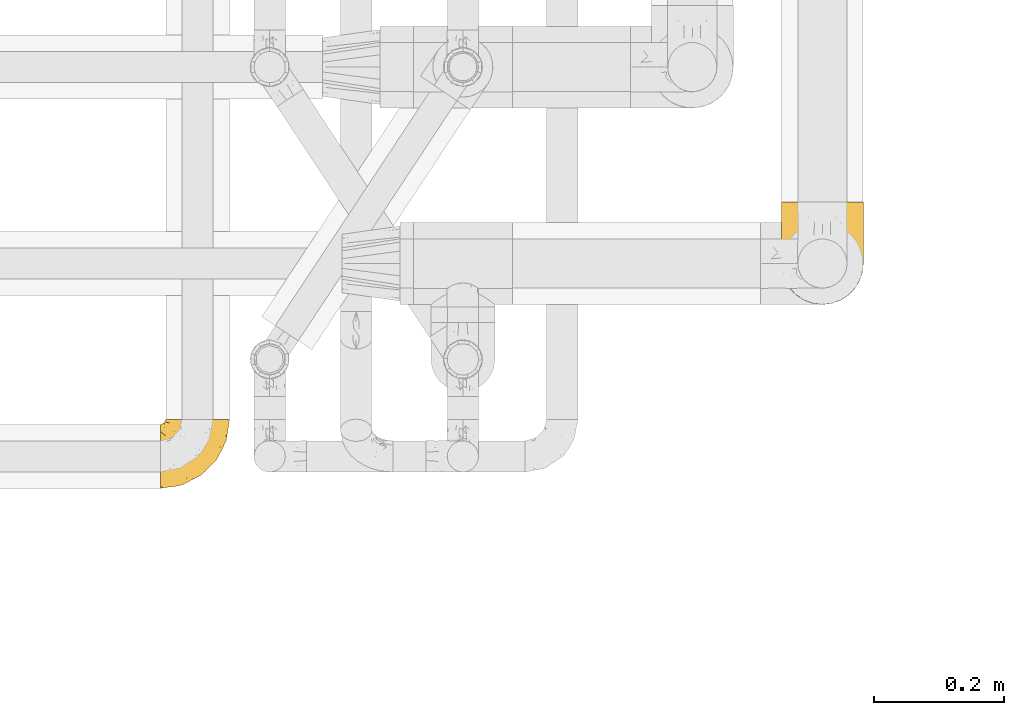
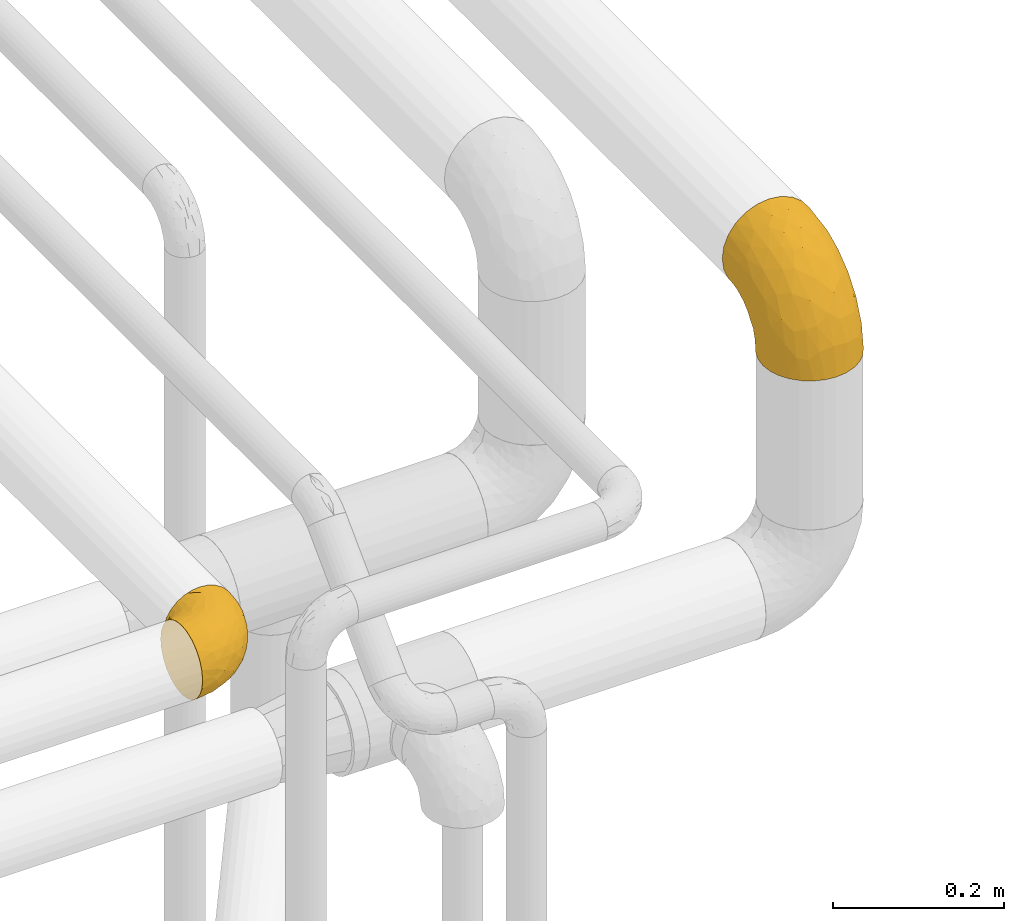
# One storey, part 391 of 827: 2 coverings.
"""IFC2X3 building model written with IfcOpenShell, lengths in millimetres."""

from ifc_helpers import new_model, entity, si_unit, converted_unit, derived_unit, direction, frame, origin, place, context, subcontext, project, spatial, faceted_brep, element, save


model = new_model("IFC2X3")

# Units and contexts
model_context = context("Model", 3, precision=0.01, world=origin(), true_north=direction((6.12303176911189e-17, 1.0)))
body_context = subcontext(model_context, "Body", "Model", "MODEL_VIEW")
ifc_project = project(units=[si_unit("LENGTHUNIT", "METRE", prefix="MILLI"), si_unit("AREAUNIT", "SQUARE_METRE"), si_unit("VOLUMEUNIT", "CUBIC_METRE"), converted_unit("PLANEANGLEUNIT", "DEGREE", entity("IfcRatioMeasure", 0.0174532925199433), si_unit("PLANEANGLEUNIT", "RADIAN"), dimensions=[0, 0, 0, 0, 0, 0, 0]), si_unit("MASSUNIT", "GRAM", prefix="KILO"), derived_unit("MASSDENSITYUNIT", [(si_unit("MASSUNIT", "GRAM", prefix="KILO"), 1), (si_unit("LENGTHUNIT", "METRE"), -3)]), derived_unit("MOMENTOFINERTIAUNIT", [(si_unit("LENGTHUNIT", "METRE"), 4)]), si_unit("TIMEUNIT", "SECOND"), si_unit("FREQUENCYUNIT", "HERTZ"), si_unit("THERMODYNAMICTEMPERATUREUNIT", "DEGREE_CELSIUS"), derived_unit("THERMALTRANSMITTANCEUNIT", [(si_unit("MASSUNIT", "GRAM", prefix="KILO"), 1), (si_unit("THERMODYNAMICTEMPERATUREUNIT", "KELVIN"), -1), (si_unit("TIMEUNIT", "SECOND"), -3)]), derived_unit("VOLUMETRICFLOWRATEUNIT", [(si_unit("LENGTHUNIT", "METRE"), 3), (si_unit("TIMEUNIT", "SECOND"), -1)]), derived_unit("MASSFLOWRATEUNIT", [(si_unit("MASSUNIT", "GRAM", prefix="KILO"), 1), (si_unit("TIMEUNIT", "SECOND"), -1)]), derived_unit("ROTATIONALFREQUENCYUNIT", [(si_unit("TIMEUNIT", "SECOND"), -1)]), si_unit("ELECTRICCURRENTUNIT", "AMPERE"), si_unit("ELECTRICVOLTAGEUNIT", "VOLT"), si_unit("POWERUNIT", "WATT"), si_unit("FORCEUNIT", "NEWTON", prefix="KILO"), si_unit("ILLUMINANCEUNIT", "LUX"), si_unit("LUMINOUSFLUXUNIT", "LUMEN"), si_unit("LUMINOUSINTENSITYUNIT", "CANDELA"), derived_unit("USERDEFINED", [(si_unit("MASSUNIT", "GRAM", prefix="KILO"), -1), (si_unit("LENGTHUNIT", "METRE"), -2), (si_unit("TIMEUNIT", "SECOND"), 3), (si_unit("LUMINOUSFLUXUNIT", "LUMEN"), 1)]), derived_unit("LINEARVELOCITYUNIT", [(si_unit("LENGTHUNIT", "METRE"), 1), (si_unit("TIMEUNIT", "SECOND"), -1)]), si_unit("PRESSUREUNIT", "PASCAL"), derived_unit("USERDEFINED", [(si_unit("LENGTHUNIT", "METRE"), -2), (si_unit("MASSUNIT", "GRAM", prefix="KILO"), 1), (si_unit("TIMEUNIT", "SECOND"), -2)]), derived_unit("LINEARFORCEUNIT", [(si_unit("MASSUNIT", "GRAM", prefix="KILO"), 1), (si_unit("LENGTHUNIT", "METRE"), 1), (si_unit("TIMEUNIT", "SECOND"), -2), (si_unit("LENGTHUNIT", "METRE"), -1)]), derived_unit("PLANARFORCEUNIT", [(si_unit("MASSUNIT", "GRAM", prefix="KILO"), 1), (si_unit("LENGTHUNIT", "METRE"), 1), (si_unit("TIMEUNIT", "SECOND"), -2), (si_unit("LENGTHUNIT", "METRE"), -2)])], contexts=[model_context])

# Site, building, storey
site_placement = place(None, origin())
site = spatial("IfcSite", under=ifc_project, at=site_placement, CompositionType="ELEMENT")
building_placement = place(site_placement, origin())
building = spatial("IfcBuilding", under=site, at=building_placement, CompositionType="ELEMENT")
storey_placement = place(building_placement, frame((0.0, 0.0, 28200.0)))
storey = spatial("IfcBuildingStorey", under=building, at=storey_placement, Name="08", CompositionType="ELEMENT", Elevation=28200.0)

# Coverings
covering_1_placement = place(storey_placement, frame((48780.39, 13868.86, 2903.4)))
element("IfcCovering", 1, at=covering_1_placement, inside=storey, Name=":ADSK_", ObjectType=":ADSK_", PredefinedType="INSULATION", context=body_context, shape_type="Brep", body=[
    faceted_brep([(126.11, 50.62, 1.6), (121.45, 37.29, 1.6), (113.94, 25.34, 1.6), (103.96, 15.35, 1.6), (92.0, 7.84, 1.6), (78.68, 3.18, 1.6), (64.65, 1.6, 1.6), (50.62, 3.18, 1.6), (37.29, 7.84, 1.6), (25.34, 15.35, 1.6), (15.35, 25.33, 1.6), (7.84, 37.29, 1.6), (3.18, 50.61, 1.6), (1.6, 64.65, 1.6), (3.18, 78.67, 1.6), (7.84, 92.0, 1.6), (15.35, 103.95, 1.6), (25.33, 113.94, 1.6), (37.29, 121.45, 1.6), (50.61, 126.11, 1.6), (64.65, 127.7, 1.6), (78.67, 126.11, 1.6), (92.0, 121.45, 1.6), (103.95, 113.94, 1.6), (113.94, 103.96, 1.6), (121.45, 92.0, 1.6), (126.11, 78.68, 1.6), (127.7, 64.65, 1.6), (64.65, 159.65, 33.55), (48.33, 159.65, 35.69), (33.12, 159.65, 41.99), (20.06, 159.65, 52.01), (10.04, 159.65, 65.07), (3.74, 159.65, 80.28), (3.01, 159.65, 85.89), (1.6, 159.65, 96.6), (3.74, 159.65, 112.91), (10.04, 159.65, 128.12), (20.06, 159.65, 141.18), (33.12, 159.65, 151.2), (48.33, 159.65, 157.5), (64.65, 159.65, 159.65), (80.96, 159.65, 157.5), (96.17, 159.65, 151.2), (109.23, 159.65, 141.18), (119.25, 159.65, 128.12), (125.55, 159.65, 112.91), (127.7, 159.65, 96.6), (126.29, 159.65, 85.89), (125.55, 159.65, 80.28), (119.25, 159.65, 65.07), (109.23, 159.65, 52.01), (96.17, 159.65, 41.99), (80.96, 159.65, 35.69), (101.1, 131.11, 145.23), (86.72, 121.84, 150.95), (98.7, 98.59, 136.48), (75.93, 132.73, 156.3), (64.65, 118.74, 154.26), (113.39, 45.67, 73.92), (111.06, 62.3, 98.94), (96.87, 49.95, 102.72), (84.07, 65.74, 124.89), (64.65, 80.62, 138.47), (64.65, 47.89, 113.35), (119.56, 117.53, 120.33), (112.75, 90.48, 118.42), (122.85, 98.53, 103.99), (125.08, 128.08, 110.05), (126.64, 107.83, 94.6), (105.78, 30.59, 62.68), (93.81, 23.56, 66.8), (96.07, 14.41, 37.71), (87.11, 94.66, 141.12), (75.77, 103.54, 148.29), (111.99, 121.36, 132.76), (64.65, 6.98, 42.5), (83.58, 9.17, 39.36), (80.96, 35.7, 96.16), (78.34, 18.43, 69.16), (122.85, 57.25, 62.71), (125.88, 81.84, 79.4), (120.97, 72.43, 88.81), (126.67, 56.38, 26.93), (122.64, 43.86, 32.13), (127.7, 103.81, 78.45), (127.7, 117.05, 85.2), (127.7, 130.29, 91.95), (107.12, 21.28, 31.66), (115.07, 34.21, 45.38), (102.81, 74.07, 118.88), (127.7, 82.79, 57.43), (127.7, 88.04, 62.69), (127.7, 93.3, 67.94), (127.7, 66.61, 13.99), (127.7, 67.95, 22.47), (127.7, 69.29, 30.95), (126.64, 66.64, 53.41), (127.7, 76.04, 44.19), (64.65, 22.77, 80.62), (127.7, 147.25, 94.63), (113.05, 120.78, 39.95), (101.81, 128.88, 33.15), (108.46, 132.53, 43.2), (126.21, 145.71, 81.77), (122.65, 132.18, 66.3), (126.55, 121.21, 75.23), (125.45, 115.88, 66.55), (126.01, 134.78, 78.18), (123.3, 113.68, 56.85), (118.99, 124.96, 54.23), (113.51, 105.67, 12.94), (104.6, 116.22, 17.42), (118.04, 103.69, 27.05), (101.6, 149.68, 44.37), (109.98, 142.04, 49.66), (92.1, 151.17, 38.88), (96.28, 140.2, 37.08), (121.05, 145.72, 66.96), (79.4, 147.4, 32.99), (79.19, 128.57, 14.52), (80.39, 136.38, 26.32), (93.14, 126.93, 22.37), (126.75, 79.77, 27.96), (125.71, 89.98, 39.47), (126.17, 79.6, 15.41), (64.65, 131.98, 17.57), (123.28, 90.59, 21.32), (64.65, 129.31, 7.61), (91.58, 133.25, 28.92), (107.1, 119.53, 28.65), (116.28, 111.1, 34.82), (116.32, 143.67, 58.27), (90.34, 123.62, 11.73), (122.74, 100.76, 40.36), (64.65, 143.67, 29.26), (126.77, 104.28, 65.12), (119.84, 112.26, 45.4), (124.71, 103.95, 53.05), (126.47, 92.99, 50.39), (37.19, 151.17, 38.88), (27.66, 144.66, 42.9), (49.9, 147.4, 32.99), (1.6, 147.25, 94.63), (50.1, 128.57, 14.52), (48.89, 136.38, 26.32), (2.88, 93.43, 50.51), (6.55, 100.15, 39.41), (3.58, 89.98, 39.47), (1.6, 103.81, 78.45), (1.6, 117.05, 85.2), (2.74, 121.21, 75.23), (11.25, 103.69, 27.05), (11.93, 110.23, 36.34), (21.09, 118.45, 28.89), (3.28, 134.78, 78.18), (6.64, 132.18, 66.3), (12.97, 143.67, 58.27), (19.31, 142.04, 49.66), (16.23, 120.78, 39.95), (21.44, 132.4, 42.42), (26.96, 127.76, 32.56), (8.24, 145.72, 66.96), (3.08, 145.71, 81.77), (10.3, 124.96, 54.23), (38.95, 123.62, 11.73), (33.01, 140.2, 37.08), (1.6, 66.61, 13.99), (1.6, 67.95, 22.47), (36.15, 126.93, 22.37), (24.69, 116.21, 17.42), (6.01, 90.59, 21.32), (2.54, 79.77, 27.96), (15.78, 105.66, 12.94), (1.6, 69.29, 30.95), (3.12, 79.6, 15.41), (37.33, 133.38, 29.3), (1.6, 82.79, 57.43), (1.6, 76.04, 44.19), (2.52, 104.28, 65.12), (3.84, 115.88, 66.55), (5.99, 113.68, 56.85), (9.35, 112.97, 46.41), (1.6, 93.3, 67.94), (4.58, 103.94, 53.04), (1.6, 130.29, 91.95), (30.59, 98.59, 136.48), (28.19, 131.11, 145.23), (17.3, 121.36, 132.76), (9.73, 117.53, 120.33), (42.57, 121.84, 150.95), (53.51, 105.45, 149.01), (53.42, 132.83, 156.33), (2.65, 107.83, 94.6), (2.62, 56.38, 26.93), (6.66, 43.85, 32.14), (6.44, 57.25, 62.71), (48.33, 35.7, 96.16), (32.42, 49.95, 102.72), (35.49, 23.55, 66.79), (2.65, 66.64, 53.41), (3.41, 81.84, 79.4), (4.21, 128.08, 110.05), (43.07, 92.46, 140.44), (23.52, 30.58, 62.68), (22.18, 21.27, 31.66), (33.1, 12.64, 29.31), (15.9, 45.66, 73.92), (14.23, 34.21, 45.39), (16.54, 90.48, 118.42), (45.22, 65.74, 124.89), (6.44, 98.53, 103.99), (8.33, 72.43, 88.81), (18.23, 62.3, 98.94), (32.99, 72.15, 122.85), (53.35, 82.52, 138.38), (48.76, 19.03, 69.18), (45.72, 9.17, 39.36)], [[[0, 1, 2, 3, 4, 5, 6, 7, 8, 9, 10, 11, 12, 13, 14, 15, 16, 17, 18, 19, 20, 21, 22, 23, 24, 25, 26, 27]], [[28, 29, 30, 31, 32, 33, 34, 35, 36, 37, 38, 39, 40, 41, 42, 43, 44, 45, 46, 47, 48, 49, 50, 51, 52, 53]], [[54, 55, 56]], [[57, 41, 58]], [[59, 60, 61]], [[62, 63, 64]], [[65, 66, 67]], [[68, 67, 69]], [[70, 71, 72]], [[55, 73, 56]], [[43, 42, 55]], [[55, 74, 73]], [[44, 75, 45]], [[44, 43, 54]], [[76, 5, 77]], [[71, 78, 79]], [[45, 75, 65]], [[46, 68, 47]], [[80, 81, 82]], [[0, 83, 84]], [[69, 85, 86, 87]], [[69, 81, 85]], [[84, 1, 0]], [[2, 88, 3]], [[4, 3, 72]], [[44, 54, 75]], [[5, 4, 77]], [[89, 2, 1]], [[72, 3, 88]], [[5, 76, 6]], [[70, 88, 89]], [[68, 65, 67]], [[88, 2, 89]], [[56, 90, 66]], [[64, 78, 62]], [[81, 91, 92, 93, 85]], [[83, 27, 94, 95, 96]], [[62, 61, 90]], [[97, 96, 98, 91]], [[80, 97, 81]], [[42, 57, 55]], [[62, 78, 61]], [[84, 89, 1]], [[78, 64, 99]], [[57, 74, 55]], [[76, 77, 79]], [[77, 72, 71]], [[82, 81, 67]], [[97, 83, 96]], [[80, 89, 84]], [[79, 78, 99]], [[71, 70, 61]], [[81, 97, 91]], [[83, 80, 84]], [[68, 87, 100, 47]], [[81, 69, 67]], [[68, 69, 87]], [[65, 46, 45]], [[65, 68, 46]], [[66, 65, 75]], [[56, 66, 75]], [[66, 60, 82]], [[71, 61, 78]], [[60, 66, 90]], [[83, 97, 80]], [[27, 83, 0]], [[59, 70, 89]], [[70, 59, 61]], [[89, 80, 59]], [[82, 59, 80]], [[55, 54, 43]], [[75, 54, 56]], [[66, 82, 67]], [[59, 82, 60]], [[41, 57, 42]], [[74, 57, 58]], [[58, 63, 74]], [[62, 74, 63]], [[74, 62, 73]], [[62, 56, 73]], [[4, 72, 77]], [[70, 72, 88]], [[76, 79, 99]], [[71, 79, 77]], [[62, 90, 56]], [[60, 90, 61]], [[101, 102, 103]], [[100, 87, 104]], [[105, 106, 107]], [[108, 104, 87]], [[107, 109, 110]], [[108, 87, 86]], [[111, 112, 113]], [[114, 51, 115]], [[116, 114, 117]], [[51, 50, 118]], [[119, 28, 53]], [[120, 121, 122]], [[98, 123, 124]], [[125, 96, 95]], [[116, 53, 52]], [[126, 121, 120]], [[104, 108, 118]], [[98, 124, 91]], [[25, 24, 127]], [[120, 128, 126]], [[122, 129, 102]], [[95, 94, 27, 26]], [[122, 102, 130]], [[125, 127, 123]], [[24, 111, 127]], [[21, 20, 128]], [[112, 130, 131]], [[48, 47, 100, 49]], [[132, 110, 115]], [[23, 111, 24]], [[129, 119, 117]], [[120, 133, 21]], [[112, 23, 22]], [[134, 113, 131]], [[121, 126, 135]], [[133, 112, 22]], [[128, 120, 21]], [[132, 51, 118]], [[120, 122, 133]], [[119, 121, 135]], [[129, 117, 102]], [[125, 26, 25]], [[26, 125, 95]], [[127, 125, 25]], [[28, 119, 135]], [[119, 53, 116]], [[127, 113, 124]], [[96, 125, 123]], [[112, 131, 113]], [[101, 103, 110]], [[85, 93, 136]], [[124, 123, 127]], [[98, 96, 123]], [[112, 111, 23]], [[127, 111, 113]], [[112, 133, 122]], [[21, 133, 22]], [[107, 110, 105]], [[110, 109, 137]], [[86, 106, 108]], [[138, 109, 136]], [[105, 118, 108]], [[107, 106, 85]], [[104, 50, 49]], [[124, 134, 139]], [[138, 93, 92]], [[92, 91, 139]], [[100, 104, 49]], [[118, 105, 132]], [[104, 118, 50]], [[110, 132, 105]], [[51, 132, 115]], [[108, 106, 105]], [[85, 106, 86]], [[114, 116, 52]], [[119, 116, 117]], [[51, 114, 52]], [[114, 115, 103]], [[117, 114, 103]], [[130, 102, 101]], [[117, 103, 102]], [[110, 103, 115]], [[130, 101, 131]], [[122, 130, 112]], [[101, 137, 131]], [[113, 134, 124]], [[137, 134, 131]], [[124, 139, 91]], [[134, 138, 139]], [[92, 139, 138]], [[110, 137, 101]], [[134, 137, 138]], [[136, 109, 107]], [[137, 109, 138]], [[85, 136, 107]], [[138, 136, 93]], [[122, 121, 129]], [[129, 121, 119]], [[30, 140, 141]], [[30, 29, 140]], [[28, 135, 142]], [[143, 35, 34, 33]], [[19, 144, 128]], [[126, 145, 135]], [[146, 147, 148]], [[149, 150, 151]], [[152, 153, 154]], [[155, 156, 151]], [[157, 31, 158]], [[159, 160, 161]], [[32, 162, 163]], [[158, 31, 30]], [[157, 164, 156]], [[126, 144, 145]], [[126, 128, 144]], [[18, 165, 19]], [[141, 166, 160]], [[14, 13, 167, 168]], [[163, 143, 33]], [[169, 165, 170]], [[18, 17, 170]], [[153, 159, 154]], [[142, 135, 145]], [[148, 171, 172]], [[159, 161, 154]], [[171, 152, 173]], [[173, 17, 16]], [[16, 15, 171]], [[158, 160, 164]], [[174, 175, 168]], [[173, 170, 17]], [[19, 128, 20]], [[174, 172, 175]], [[165, 169, 144]], [[162, 157, 156]], [[175, 172, 171]], [[144, 169, 145]], [[176, 169, 161]], [[166, 140, 142]], [[175, 171, 15]], [[168, 175, 14]], [[14, 175, 15]], [[142, 145, 176]], [[28, 142, 29]], [[148, 177, 146]], [[148, 178, 177]], [[152, 171, 148]], [[179, 180, 181]], [[164, 180, 156]], [[174, 178, 172]], [[148, 172, 178]], [[171, 173, 16]], [[170, 173, 152]], [[19, 165, 144]], [[170, 165, 18]], [[153, 182, 159]], [[146, 183, 184]], [[181, 180, 164]], [[180, 151, 156]], [[163, 155, 185]], [[155, 150, 185]], [[162, 156, 155]], [[143, 163, 185]], [[180, 179, 149]], [[32, 163, 33]], [[163, 162, 155]], [[31, 162, 32]], [[31, 157, 162]], [[164, 157, 158]], [[149, 151, 180]], [[155, 151, 150]], [[142, 140, 29]], [[141, 140, 166]], [[176, 145, 169]], [[30, 141, 158]], [[164, 160, 159]], [[158, 141, 160]], [[166, 161, 160]], [[154, 169, 170]], [[169, 154, 161]], [[152, 154, 170]], [[147, 152, 148]], [[153, 147, 182]], [[181, 182, 184]], [[164, 159, 182]], [[161, 166, 176]], [[142, 176, 166]], [[183, 146, 177]], [[184, 182, 147]], [[184, 147, 146]], [[152, 147, 153]], [[182, 181, 164]], [[179, 184, 183]], [[184, 179, 181]], [[149, 179, 183]], [[186, 187, 188]], [[37, 36, 189]], [[190, 191, 192]], [[193, 185, 150, 149]], [[194, 195, 196]], [[197, 198, 199]], [[200, 201, 177]], [[193, 202, 185]], [[203, 190, 186]], [[202, 189, 36]], [[41, 40, 192]], [[204, 205, 199]], [[9, 8, 206]], [[187, 190, 39]], [[40, 39, 190]], [[38, 37, 188]], [[207, 208, 204]], [[202, 35, 143, 185]], [[39, 38, 187]], [[195, 11, 208]], [[201, 149, 183, 177]], [[188, 189, 209]], [[197, 64, 210]], [[186, 188, 209]], [[13, 12, 194]], [[211, 201, 212]], [[12, 11, 195]], [[193, 201, 211]], [[212, 201, 196]], [[10, 208, 11]], [[213, 214, 209]], [[64, 63, 215]], [[216, 197, 199]], [[8, 217, 206]], [[7, 217, 8]], [[203, 191, 190]], [[7, 6, 76]], [[208, 205, 204]], [[205, 10, 9]], [[199, 205, 206]], [[7, 76, 217]], [[205, 208, 10]], [[216, 76, 99]], [[200, 177, 178, 174]], [[64, 197, 99]], [[63, 58, 191]], [[208, 196, 195]], [[196, 200, 194]], [[198, 197, 210]], [[216, 199, 217]], [[201, 193, 149]], [[202, 193, 211]], [[202, 211, 189]], [[35, 202, 36]], [[211, 212, 209]], [[37, 189, 188]], [[211, 209, 189]], [[213, 198, 214]], [[200, 174, 194]], [[201, 200, 196]], [[214, 198, 210]], [[213, 207, 198]], [[194, 174, 168, 167, 13]], [[195, 194, 12]], [[198, 204, 199]], [[204, 198, 207]], [[212, 207, 213]], [[196, 208, 207]], [[188, 187, 38]], [[190, 187, 186]], [[207, 212, 196]], [[209, 212, 213]], [[214, 203, 186]], [[191, 215, 63]], [[191, 203, 215]], [[192, 191, 58]], [[41, 192, 58]], [[190, 192, 40]], [[203, 210, 215]], [[64, 215, 210]], [[199, 206, 217]], [[9, 206, 205]], [[76, 216, 217]], [[99, 197, 216]], [[203, 214, 210]], [[209, 214, 186]]]),
])
covering_2_placement = place(storey_placement, frame((47825.42, 13586.09, 2949.25)))
element("IfcCovering", 2, at=covering_2_placement, inside=storey, Name=":ADSK_", ObjectType=":ADSK_", PredefinedType="INSULATION", context=body_context, shape_type="Brep", body=[
    faceted_brep([(58.6, 107.75, 99.9), (69.54, 107.75, 98.66), (79.93, 107.75, 95.02), (89.25, 107.75, 89.17), (97.03, 107.75, 81.38), (102.88, 107.75, 72.06), (106.51, 107.75, 61.68), (107.75, 107.75, 50.75), (106.51, 107.75, 39.8), (102.87, 107.75, 29.41), (97.02, 107.75, 20.09), (89.23, 107.75, 12.31), (79.91, 107.75, 6.46), (69.53, 107.75, 2.83), (58.6, 107.75, 1.6), (52.89, 107.75, 2.24), (47.65, 107.75, 2.83), (42.46, 107.75, 4.65), (37.26, 107.75, 6.47), (27.94, 107.75, 12.32), (20.16, 107.75, 20.11), (14.31, 107.75, 29.43), (10.68, 107.75, 39.81), (9.45, 107.75, 50.75), (10.68, 107.75, 61.69), (14.32, 107.75, 72.08), (20.17, 107.75, 81.4), (27.96, 107.75, 89.18), (37.28, 107.75, 95.03), (42.47, 107.75, 96.85), (47.66, 107.75, 98.66), (52.89, 107.75, 99.25), (55.75, 107.75, 99.57), (1.6, 98.22, 38.02), (1.6, 93.31, 26.17), (1.6, 89.4, 21.08), (1.6, 85.5, 15.99), (1.6, 80.41, 12.09), (1.6, 75.32, 8.18), (1.6, 69.39, 5.73), (1.6, 63.47, 3.27), (1.6, 56.48, 2.35), (1.6, 53.61, 1.97), (1.6, 50.75, 1.6), (1.6, 38.02, 3.27), (1.6, 26.17, 8.18), (1.6, 15.99, 15.99), (1.6, 8.18, 26.17), (1.6, 3.27, 38.02), (1.6, 1.6, 50.75), (1.6, 3.27, 63.47), (1.6, 8.18, 75.32), (1.6, 15.99, 85.5), (1.6, 26.17, 93.31), (1.6, 38.02, 98.22), (1.6, 50.75, 99.9), (1.6, 56.48, 99.14), (1.6, 63.47, 98.22), (1.6, 69.39, 95.77), (1.6, 75.32, 93.31), (1.6, 80.41, 89.4), (1.6, 85.5, 85.5), (1.6, 89.4, 80.41), (1.6, 93.31, 75.32), (1.6, 98.22, 63.47), (1.6, 99.9, 50.75), (69.96, 27.53, 59.31), (59.59, 25.32, 73.08), (51.96, 16.29, 63.72), (34.4, 6.79, 50.75), (23.37, 4.51, 58.64), (13.68, 3.51, 50.75), (41.52, 17.47, 76.74), (26.26, 7.6, 67.68), (20.18, 12.27, 78.92), (72.33, 70.89, 94.31), (65.88, 87.17, 98.76), (57.55, 67.3, 98.4), (23.76, 31.65, 94.57), (46.5, 33.58, 89.91), (46.57, 47.23, 96.32), (21.17, 43.26, 98.79), (23.41, 55.08, 99.9), (17.92, 53.99, 99.9), (12.43, 52.9, 99.9), (9.72, 52.36, 99.9), (7.01, 51.82, 99.9), (26.77, 21.5, 87.31), (76.59, 89.94, 95.61), (95.55, 60.45, 60.43), (102.57, 83.0, 65.24), (92.89, 64.79, 72.87), (54.26, 85.93, 99.9), (51.17, 81.31, 99.9), (48.08, 76.69, 99.9), (44.99, 72.06, 99.9), (41.9, 67.44, 99.9), (85.16, 88.74, 90.65), (85.97, 45.98, 63.14), (59.58, 47.13, 91.89), (99.5, 89.4, 75.25), (105.83, 95.66, 50.75), (53.59, 28.5, 82.18), (67.0, 42.81, 85.08), (71.56, 38.28, 76.93), (87.47, 45.35, 50.75), (75.73, 33.61, 50.75), (92.24, 82.57, 83.02), (58.06, 105.04, 99.9), (57.52, 102.33, 99.9), (56.44, 96.91, 99.9), (55.35, 91.42, 99.9), (81.33, 65.92, 87.13), (80.35, 53.11, 80.85), (39.44, 54.37, 99.17), (102.55, 74.94, 50.75), (37.28, 64.35, 99.9), (32.65, 61.26, 99.9), (28.03, 58.17, 99.9), (63.99, 21.87, 50.75), (74.55, 34.79, 67.61), (83.62, 48.48, 72.25), (95.01, 60.15, 50.75), (49.19, 14.33, 50.75), (46.96, 99.07, 98.69), (8.77, 60.55, 99.01), (18.28, 64.18, 98.79), (11.68, 64.36, 98.29), (11.79, 103.17, 68.51), (15.69, 101.69, 76.82), (42.49, 87.75, 98.54), (47.41, 89.38, 99.3), (7.94, 88.34, 83.57), (9.27, 82.14, 89.47), (7.98, 94.51, 75.76), (13.4, 89.64, 84.86), (13.04, 98.41, 75.89), (7.36, 99.71, 64.77), (23.46, 89.37, 90.83), (30.46, 88.21, 94.62), (26.54, 95.2, 90.37), (6.76, 79.14, 91.18), (26.46, 101.22, 88.65), (20.77, 99.41, 84.11), (20.68, 84.72, 91.75), (40.26, 97.47, 96.86), (7.15, 102.19, 50.75), (9.28, 104.02, 58.97), (38.78, 82.66, 98.37), (18.27, 95.42, 83.91), (31.78, 78.67, 97.52), (12.75, 72.69, 95.55), (22.96, 66.46, 98.76), (17.55, 75.3, 95.26), (27.63, 72.74, 98.04), (15.23, 82.93, 90.65), (33.25, 99.27, 93.51), (32.43, 93.51, 94.16), (27.9, 67.35, 99.1), (7.97, 94.51, 25.73), (15.22, 82.94, 10.84), (7.93, 88.33, 17.92), (13.38, 89.64, 16.64), (13.12, 103.62, 30.44), (42.49, 87.74, 2.95), (47.4, 89.38, 2.19), (51.17, 81.31, 1.6), (40.24, 97.47, 4.63), (20.76, 99.41, 17.39), (12.43, 52.9, 1.6), (7.01, 51.82, 1.6), (4.31, 51.28, 1.6), (26.44, 101.21, 12.86), (26.52, 95.19, 11.13), (11.68, 64.36, 3.2), (12.75, 72.69, 5.94), (9.27, 82.13, 12.02), (17.55, 75.3, 6.23), (6.76, 79.14, 10.31), (33.21, 99.28, 8.0), (32.41, 93.51, 7.34), (8.77, 60.55, 2.48), (22.96, 66.46, 2.73), (18.48, 63.96, 2.64), (56.44, 96.91, 1.6), (46.95, 99.06, 2.8), (7.36, 99.7, 36.71), (17.92, 53.99, 1.6), (23.41, 55.08, 1.6), (9.85, 103.3, 38.59), (57.52, 102.33, 1.6), (56.98, 99.62, 1.6), (48.08, 76.69, 1.6), (38.78, 82.66, 3.12), (18.25, 95.42, 17.59), (44.99, 72.06, 1.6), (31.74, 78.68, 3.98), (30.45, 88.2, 6.87), (27.63, 72.75, 3.45), (20.65, 84.74, 9.76), (55.35, 91.42, 1.6), (54.26, 85.93, 1.6), (13.03, 98.41, 25.62), (23.44, 89.37, 10.67), (27.9, 67.35, 2.39), (32.65, 61.26, 1.6), (28.03, 58.17, 1.6), (37.28, 64.35, 1.6), (41.9, 67.44, 1.6), (39.74, 54.08, 2.4), (23.37, 4.51, 42.85), (26.77, 21.5, 14.18), (46.18, 33.43, 11.56), (53.54, 28.5, 19.27), (41.53, 17.47, 24.75), (59.61, 25.36, 28.37), (76.79, 90.18, 5.95), (66.11, 86.97, 2.79), (21.17, 43.26, 2.71), (51.96, 16.29, 37.78), (26.26, 7.6, 33.81), (20.18, 12.27, 22.57), (23.76, 31.65, 6.92), (92.88, 64.79, 28.61), (102.57, 83.0, 36.24), (95.54, 60.44, 41.05), (71.63, 38.35, 24.55), (74.55, 34.8, 33.88), (72.51, 71.54, 7.11), (69.96, 27.53, 42.18), (92.23, 82.57, 18.46), (85.15, 88.74, 10.84), (80.45, 53.19, 20.69), (83.65, 48.49, 29.27), (57.57, 67.28, 3.1), (63.68, 52.32, 9.18), (85.95, 45.94, 38.38), (99.49, 89.4, 26.23), (81.23, 65.75, 14.34), (47.07, 46.73, 5.46), (66.99, 42.82, 16.39)], [[[0, 1, 2, 3, 4, 5, 6, 7, 8, 9, 10, 11, 12, 13, 14, 15, 16, 17, 18, 19, 20, 21, 22, 23, 24, 25, 26, 27, 28, 29, 30, 31, 32]], [[33, 34, 35, 36, 37, 38, 39, 40, 41, 42, 43, 44, 45, 46, 47, 48, 49, 50, 51, 52, 53, 54, 55, 56, 57, 58, 59, 60, 61, 62, 63, 64, 65]], [[66, 67, 68]], [[69, 70, 71]], [[68, 72, 73]], [[73, 72, 74]], [[75, 76, 77]], [[78, 79, 80]], [[51, 50, 73]], [[81, 82, 83, 84, 85, 86, 55]], [[52, 87, 53]], [[74, 52, 51]], [[2, 1, 88]], [[89, 90, 91]], [[77, 92, 93, 94, 95, 96]], [[55, 54, 81]], [[78, 53, 87]], [[5, 90, 6]], [[88, 76, 75]], [[97, 3, 2]], [[89, 91, 98]], [[99, 80, 79]], [[90, 5, 100]], [[74, 87, 52]], [[100, 5, 4]], [[90, 101, 6]], [[79, 102, 103]], [[102, 67, 104]], [[105, 98, 106]], [[107, 4, 3]], [[76, 0, 108, 109, 110, 111, 92]], [[107, 112, 113]], [[114, 77, 96]], [[89, 115, 90]], [[114, 96, 116, 117, 118, 82]], [[75, 97, 88]], [[119, 66, 68]], [[50, 71, 70]], [[100, 91, 90]], [[99, 77, 80]], [[102, 104, 103]], [[97, 107, 3]], [[80, 81, 78]], [[107, 97, 112]], [[68, 73, 70]], [[66, 98, 120]], [[78, 81, 54]], [[114, 81, 80]], [[53, 78, 54]], [[78, 87, 79]], [[102, 87, 72]], [[79, 103, 99]], [[4, 107, 100]], [[91, 100, 107]], [[88, 97, 2]], [[112, 97, 75]], [[99, 112, 75]], [[103, 104, 113]], [[91, 121, 98]], [[89, 105, 122, 115]], [[101, 90, 115]], [[101, 7, 6]], [[88, 1, 76]], [[0, 76, 1]], [[92, 77, 76]], [[73, 74, 51]], [[87, 74, 72]], [[81, 114, 82]], [[77, 114, 80]], [[87, 102, 79]], [[67, 102, 72]], [[68, 67, 72]], [[67, 120, 104]], [[120, 121, 104]], [[104, 121, 113]], [[121, 120, 98]], [[91, 107, 113]], [[91, 113, 121]], [[103, 113, 112]], [[106, 98, 66]], [[105, 89, 98]], [[106, 66, 119]], [[67, 66, 120]], [[68, 69, 123, 119]], [[50, 49, 71]], [[50, 70, 73]], [[112, 99, 103]], [[77, 99, 75]], [[69, 68, 70]], [[29, 124, 110]], [[84, 83, 125]], [[126, 82, 118]], [[59, 58, 127]], [[25, 128, 129]], [[130, 93, 131]], [[132, 62, 133]], [[134, 135, 136]], [[137, 65, 64]], [[64, 134, 137]], [[138, 139, 140]], [[111, 110, 124, 92]], [[134, 136, 137]], [[134, 64, 63]], [[141, 61, 60]], [[125, 58, 57]], [[142, 143, 140]], [[142, 26, 143]], [[127, 83, 82]], [[28, 124, 29]], [[108, 0, 32, 31, 30, 110, 109]], [[30, 29, 110]], [[135, 144, 138]], [[28, 145, 124]], [[57, 56, 55, 86, 85, 84]], [[146, 147, 23]], [[24, 23, 147]], [[25, 143, 26]], [[95, 94, 148]], [[24, 128, 25]], [[149, 138, 143]], [[124, 145, 131]], [[127, 58, 125]], [[150, 148, 139]], [[127, 126, 151]], [[151, 59, 127]], [[152, 151, 126]], [[153, 154, 155]], [[153, 133, 141]], [[145, 28, 27]], [[142, 156, 27]], [[157, 148, 130]], [[61, 133, 62]], [[134, 132, 135]], [[147, 128, 24]], [[65, 137, 146]], [[146, 137, 147]], [[128, 137, 136]], [[137, 128, 147]], [[128, 136, 129]], [[149, 129, 136]], [[25, 129, 143]], [[158, 152, 117]], [[152, 118, 117]], [[153, 151, 152]], [[158, 116, 154]], [[144, 150, 138]], [[153, 152, 158]], [[133, 153, 155]], [[133, 155, 132]], [[60, 151, 141]], [[135, 132, 155]], [[134, 63, 132]], [[144, 135, 155]], [[135, 138, 149]], [[155, 154, 144]], [[150, 154, 96]], [[154, 150, 144]], [[148, 94, 130]], [[82, 126, 127]], [[118, 152, 126]], [[150, 96, 95]], [[139, 148, 157]], [[150, 95, 148]], [[93, 92, 131]], [[130, 145, 156]], [[130, 94, 93]], [[84, 125, 57]], [[127, 125, 83]], [[140, 139, 157]], [[150, 139, 138]], [[140, 157, 142]], [[138, 140, 143]], [[156, 142, 157]], [[27, 26, 142]], [[130, 156, 157]], [[145, 27, 156]], [[132, 63, 62]], [[124, 131, 92]], [[130, 131, 145]], [[129, 149, 143]], [[135, 149, 136]], [[141, 133, 61]], [[60, 59, 151]], [[141, 151, 153]], [[116, 96, 154]], [[153, 158, 154]], [[158, 117, 116]], [[34, 33, 159]], [[160, 161, 162]], [[22, 21, 163]], [[164, 165, 166]], [[19, 18, 167]], [[168, 21, 20]], [[42, 41, 40, 169, 170, 171, 43]], [[172, 173, 168]], [[174, 38, 175]], [[176, 177, 178]], [[179, 164, 180]], [[40, 181, 169]], [[182, 183, 175]], [[17, 184, 185]], [[65, 146, 186]], [[187, 174, 188]], [[23, 22, 189]], [[174, 39, 38]], [[15, 14, 190, 191, 184, 16]], [[181, 40, 39]], [[192, 193, 164]], [[194, 163, 168]], [[33, 186, 159]], [[180, 173, 172]], [[195, 196, 193]], [[18, 185, 167]], [[173, 180, 197]], [[198, 199, 196]], [[200, 201, 185, 184]], [[184, 17, 16]], [[18, 17, 185]], [[202, 159, 186]], [[194, 168, 203]], [[189, 163, 202]], [[204, 205, 182]], [[187, 181, 174]], [[160, 177, 176]], [[206, 183, 182]], [[206, 182, 205]], [[201, 165, 185]], [[165, 164, 167]], [[172, 179, 180]], [[202, 194, 162]], [[176, 161, 160]], [[65, 186, 33]], [[163, 189, 22]], [[175, 177, 182]], [[174, 183, 188]], [[177, 198, 204]], [[199, 160, 162]], [[198, 207, 204]], [[175, 38, 37]], [[198, 177, 160]], [[178, 177, 175]], [[176, 35, 161]], [[34, 159, 161]], [[162, 161, 159]], [[202, 162, 159]], [[199, 162, 203]], [[196, 199, 203]], [[198, 160, 199]], [[193, 197, 180]], [[208, 198, 196]], [[188, 183, 206]], [[175, 183, 174]], [[193, 192, 195]], [[195, 208, 196]], [[197, 196, 203]], [[180, 164, 193]], [[168, 163, 21]], [[166, 165, 201]], [[166, 192, 164]], [[189, 202, 186]], [[186, 146, 189]], [[23, 189, 146]], [[174, 181, 39]], [[169, 181, 187]], [[196, 197, 193]], [[173, 203, 168]], [[203, 173, 197]], [[172, 168, 20]], [[20, 19, 172]], [[179, 172, 19]], [[19, 167, 179]], [[164, 179, 167]], [[35, 176, 36]], [[35, 34, 161]], [[185, 165, 167]], [[162, 194, 203]], [[163, 194, 202]], [[176, 178, 36]], [[37, 36, 178]], [[175, 37, 178]], [[177, 204, 182]], [[207, 198, 208]], [[207, 205, 204]], [[209, 188, 206, 205, 207, 208]], [[48, 210, 71]], [[211, 212, 213]], [[214, 213, 215]], [[216, 217, 13]], [[218, 43, 171, 170, 169, 187, 188]], [[219, 220, 214]], [[47, 46, 221]], [[210, 48, 220]], [[211, 222, 212]], [[222, 45, 44]], [[221, 220, 47]], [[47, 220, 48]], [[221, 211, 214]], [[223, 224, 225]], [[211, 46, 45]], [[226, 227, 215]], [[43, 218, 44]], [[217, 216, 228]], [[219, 215, 229]], [[14, 13, 217]], [[224, 9, 8]], [[10, 230, 11]], [[11, 231, 12]], [[232, 223, 233]], [[234, 208, 195, 192, 166, 201]], [[235, 234, 228]], [[222, 44, 218]], [[106, 229, 236]], [[224, 237, 9]], [[231, 238, 228]], [[9, 237, 10]], [[115, 224, 101]], [[239, 234, 235]], [[231, 11, 230]], [[223, 230, 237]], [[224, 8, 101]], [[223, 236, 233]], [[225, 115, 122, 105]], [[216, 12, 231]], [[209, 234, 239]], [[210, 219, 69]], [[219, 214, 215]], [[229, 119, 219]], [[209, 218, 188]], [[239, 212, 222]], [[239, 222, 218]], [[45, 222, 211]], [[235, 212, 239]], [[213, 212, 240]], [[223, 237, 224]], [[230, 10, 237]], [[238, 231, 230]], [[216, 231, 228]], [[232, 230, 223]], [[235, 238, 240]], [[115, 225, 224]], [[233, 236, 227]], [[8, 7, 101]], [[234, 209, 208]], [[218, 209, 239]], [[217, 228, 234]], [[13, 12, 216]], [[234, 201, 217]], [[217, 201, 200, 184, 191, 190, 14]], [[211, 221, 46]], [[220, 221, 214]], [[71, 210, 69]], [[71, 49, 48]], [[219, 210, 220]], [[226, 215, 213]], [[211, 213, 214]], [[226, 213, 240]], [[215, 227, 229]], [[232, 240, 238]], [[233, 227, 226]], [[232, 233, 226]], [[236, 223, 225]], [[240, 232, 226]], [[232, 238, 230]], [[225, 105, 236]], [[236, 105, 106]], [[236, 229, 227]], [[123, 69, 219, 119]], [[106, 119, 229]], [[238, 235, 228]], [[212, 235, 240]]]),
])

save(model, "model.ifc")
